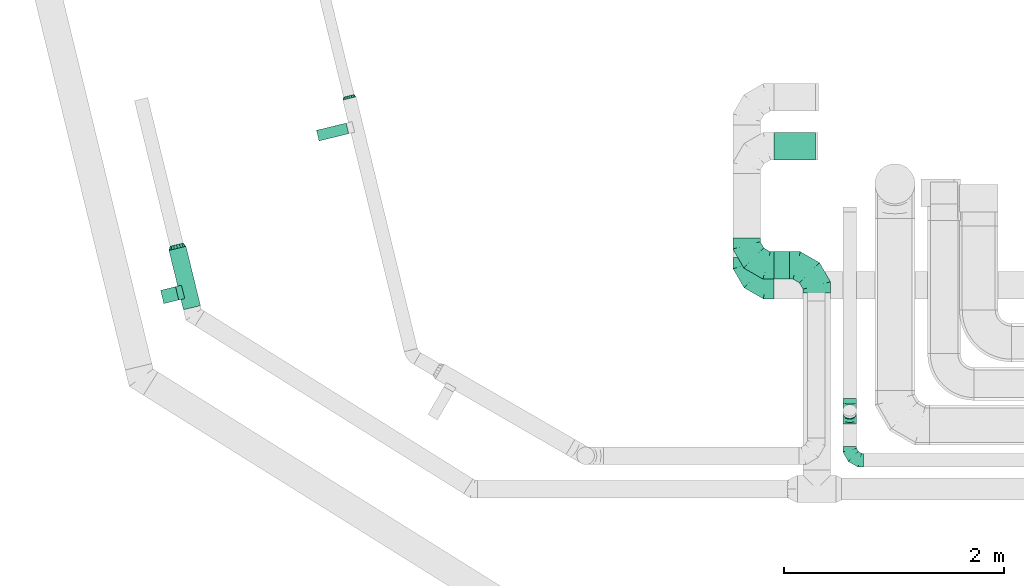
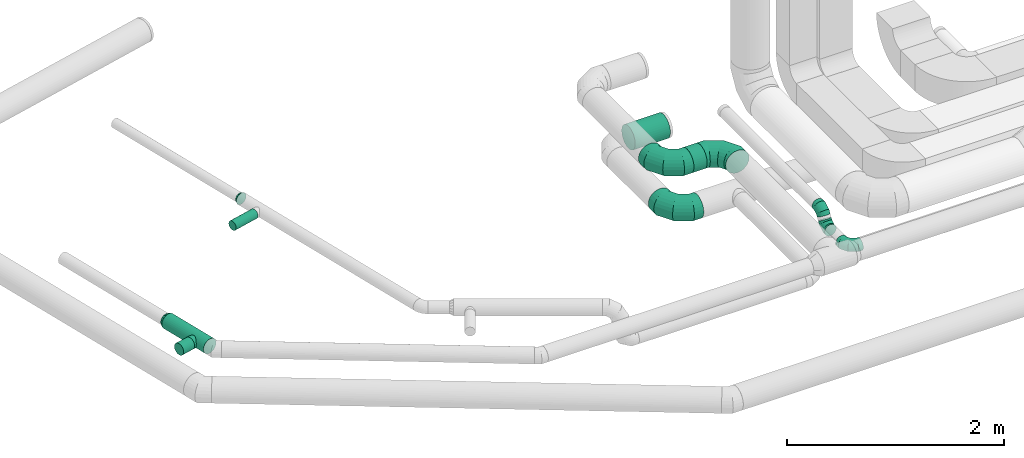
# One storey, part 36 of 92: 9 flow fittings, 5 flow segments.
"""IFC2X3 building model written with IfcOpenShell, lengths in millimetres."""

from ifc_helpers import new_model, entity, si_unit, converted_unit, derived_unit, direction, frame, origin, origin_2d_with_axis, place, context, subcontext, project, spatial, circle, extrude, faceted_brep, source, transform, mapped, material, type_object, type_shapes, element, save


model = new_model("IFC2X3")

# Units and contexts
model_context = context("Model", 3, precision=0.01, world=origin(), true_north=direction((6.12303176911189e-17, 1.0)))
body_context = subcontext(model_context, "Body", "Model", "MODEL_VIEW")
ifc_project = project(units=[si_unit("LENGTHUNIT", "METRE", prefix="MILLI"), si_unit("AREAUNIT", "SQUARE_METRE"), si_unit("VOLUMEUNIT", "CUBIC_METRE"), converted_unit("PLANEANGLEUNIT", "DEGREE", entity("IfcRatioMeasure", 0.0174532925199433), si_unit("PLANEANGLEUNIT", "RADIAN"), dimensions=[0, 0, 0, 0, 0, 0, 0]), si_unit("MASSUNIT", "GRAM", prefix="KILO"), derived_unit("MASSDENSITYUNIT", [(si_unit("MASSUNIT", "GRAM", prefix="KILO"), 1), (si_unit("LENGTHUNIT", "METRE"), -3)]), derived_unit("MOMENTOFINERTIAUNIT", [(si_unit("LENGTHUNIT", "METRE"), 4)]), si_unit("TIMEUNIT", "SECOND"), si_unit("FREQUENCYUNIT", "HERTZ"), si_unit("THERMODYNAMICTEMPERATUREUNIT", "DEGREE_CELSIUS"), derived_unit("THERMALTRANSMITTANCEUNIT", [(si_unit("MASSUNIT", "GRAM", prefix="KILO"), 1), (si_unit("THERMODYNAMICTEMPERATUREUNIT", "KELVIN"), -1), (si_unit("TIMEUNIT", "SECOND"), -3)]), derived_unit("VOLUMETRICFLOWRATEUNIT", [(si_unit("LENGTHUNIT", "METRE"), 3), (si_unit("TIMEUNIT", "SECOND"), -1)]), derived_unit("MASSFLOWRATEUNIT", [(si_unit("MASSUNIT", "GRAM", prefix="KILO"), 1), (si_unit("TIMEUNIT", "SECOND"), -1)]), derived_unit("ROTATIONALFREQUENCYUNIT", [(si_unit("TIMEUNIT", "SECOND"), -1)]), si_unit("ELECTRICCURRENTUNIT", "AMPERE"), si_unit("ELECTRICVOLTAGEUNIT", "VOLT"), si_unit("POWERUNIT", "WATT"), si_unit("FORCEUNIT", "NEWTON", prefix="KILO"), si_unit("ILLUMINANCEUNIT", "LUX"), si_unit("LUMINOUSFLUXUNIT", "LUMEN"), si_unit("LUMINOUSINTENSITYUNIT", "CANDELA"), derived_unit("USERDEFINED", [(si_unit("MASSUNIT", "GRAM", prefix="KILO"), -1), (si_unit("LENGTHUNIT", "METRE"), -2), (si_unit("TIMEUNIT", "SECOND"), 3), (si_unit("LUMINOUSFLUXUNIT", "LUMEN"), 1)]), derived_unit("LINEARVELOCITYUNIT", [(si_unit("LENGTHUNIT", "METRE"), 1), (si_unit("TIMEUNIT", "SECOND"), -1)]), si_unit("PRESSUREUNIT", "PASCAL"), derived_unit("USERDEFINED", [(si_unit("LENGTHUNIT", "METRE"), -2), (si_unit("MASSUNIT", "GRAM", prefix="KILO"), 1), (si_unit("TIMEUNIT", "SECOND"), -2)]), derived_unit("LINEARFORCEUNIT", [(si_unit("MASSUNIT", "GRAM", prefix="KILO"), 1), (si_unit("LENGTHUNIT", "METRE"), 1), (si_unit("TIMEUNIT", "SECOND"), -2), (si_unit("LENGTHUNIT", "METRE"), -1)]), derived_unit("PLANARFORCEUNIT", [(si_unit("MASSUNIT", "GRAM", prefix="KILO"), 1), (si_unit("LENGTHUNIT", "METRE"), 1), (si_unit("TIMEUNIT", "SECOND"), -2), (si_unit("LENGTHUNIT", "METRE"), -2)])], contexts=[model_context])

# Site, building, storey
site_placement = place(None, origin())
site = spatial("IfcSite", under=ifc_project, at=site_placement, CompositionType="ELEMENT")
building_placement = place(site_placement, origin())
building = spatial("IfcBuilding", under=site, at=building_placement, CompositionType="ELEMENT")
storey_placement = place(building_placement, frame((0.0, 0.0, 4200.0)))
storey = spatial("IfcBuildingStorey", under=building, at=storey_placement, CompositionType="ELEMENT", Elevation=4200.0)

# Flow segments
duct_segment_type = type_object("IfcDuctSegmentType", PredefinedType="NOTDEFINED")
flow_segment_1_placement = place(storey_placement, frame((1987.11, 12867.99, 3218.4)))
element("IfcFlowSegment", 1, at=flow_segment_1_placement, inside=storey, type_object=duct_segment_type, context=body_context, shape_type="SweptSolid", body=[
    extrude(circle(Radius=80.0, at=origin_2d_with_axis()), frame((79.32, 560.84, 81.6), z_axis=(0.236826092990331, -0.971552058141475, 0.0), x_axis=(0.971552058141475, 0.236826092990331, 0.0)), (0.0, 0.0, 1.0), 556.118650423203),
])
flow_segment_2_placement = place(storey_placement, frame((1910.85, 12924.11, 3235.9)))
element("IfcFlowSegment", 2, at=flow_segment_2_placement, inside=storey, type_object=duct_segment_type, context=body_context, shape_type="SweptSolid", body=[
    extrude(circle(Radius=62.5, at=origin_2d_with_axis()), frame((16.4, 62.32, 64.1), z_axis=(0.971552058141405, 0.236826092990615, 0.0), x_axis=(-0.236826092990615, 0.971552058141405, 0.0)), (0.0, 0.0, 1.0), 140.00000000002),
])
flow_segment_3_placement = place(storey_placement, frame((7501.8, 14233.04, 2773.4)))
element("IfcFlowSegment", 3, at=flow_segment_3_placement, inside=storey, type_object=duct_segment_type, context=body_context, shape_type="SweptSolid", body=[
    extrude(circle(Radius=125.0, at=origin_2d_with_axis()), frame((0.0, 126.6, 126.6), z_axis=(1.0, 0.0, 0.0), x_axis=(0.0, -1.0, 0.0)), (0.0, 0.0, 1.0), 374.869370000043),
])
flow_segment_4_placement = place(storey_placement, frame((3330.66, 14405.86, 3251.25)))
element("IfcFlowSegment", 4, at=flow_segment_4_placement, inside=storey, type_object=duct_segment_type, context=body_context, shape_type="SweptSolid", body=[
    extrude(circle(Radius=50.0, at=origin_2d_with_axis()), frame((13.43, 50.17, 51.6), z_axis=(0.971566689307943, 0.236766062236974, 0.0), x_axis=(-0.236766062236974, 0.971566689307943, 0.0)), (0.0, 0.0, 1.0), 278.877035459787),
])
flow_segment_5_placement = place(storey_placement, frame((7500.09, 13147.27, 3173.4)))
element("IfcFlowSegment", 5, at=flow_segment_5_placement, inside=storey, type_object=duct_segment_type, context=body_context, shape_type="SweptSolid", body=[
    extrude(circle(Radius=125.0, at=origin_2d_with_axis()), frame((0.0, 126.6, 126.6), z_axis=(1.0, 0.0, 0.0), x_axis=(0.0, 1.0, 0.0)), (0.0, 0.0, 1.0), 140.00000000002),
])

# Flow fittings
ifc_material = material()
duct_fitting_type_1 = type_object("IfcDuctFittingType", PredefinedType="NOTDEFINED", material=ifc_material)
shared_shape_1 = source(origin(), body_context, "Body", "Brep", [
    faceted_brep([(-250.0, 0.0, -125.0), (-250.0, -32.35, -120.74), (-250.0, -62.5, -108.25), (-250.0, -88.39, -88.39), (-250.0, -108.25, -62.5), (-250.0, -120.74, -32.35), (-250.0, -125.0, 0.0), (-250.0, -120.74, 32.35), (-250.0, -108.25, 62.5), (-250.0, -88.39, 88.39), (-250.0, -62.5, 108.25), (-250.0, -32.35, 120.74), (-250.0, 0.0, 125.0), (-250.0, 32.35, 120.74), (-250.0, 62.5, 108.25), (-250.0, 88.39, 88.39), (-250.0, 108.25, 62.5), (-250.0, 120.74, 32.35), (-250.0, 125.0, 0.0), (-250.0, 120.74, -32.35), (-250.0, 108.25, -62.5), (-250.0, 88.39, -88.39), (-250.0, 62.5, -108.25), (-250.0, 32.35, -120.74), (-191.68, 32.35, 120.74), (-199.76, 62.5, 108.25), (-183.01, 0.0, 125.0), (-206.7, 88.39, 88.39), (-215.37, 120.74, 32.35), (-216.51, 125.0, 0.0), (-212.02, 108.25, 62.5), (-212.02, 108.25, -62.5), (-206.7, 88.39, -88.39), (-215.37, 120.74, -32.35), (-191.68, 32.35, -120.74), (-183.01, 0.0, -125.0), (-199.76, 62.5, -108.25), (-174.34, -32.35, -120.74), (-166.27, -62.5, -108.25), (-159.33, -88.39, -88.39), (-154.01, -108.25, -62.5), (-150.66, -120.74, -32.35), (-149.52, -125.0, 0.0), (-150.66, -120.74, 32.35), (-154.01, -108.25, 62.5), (-159.33, -88.39, 88.39), (-166.27, -62.5, 108.25), (-174.34, -32.35, 120.74), (-90.67, 90.67, 120.74), (-112.74, 112.74, 108.25), (-66.99, 66.99, 125.0), (-131.69, 131.69, 88.39), (-146.23, 146.23, 62.5), (-155.38, 155.38, 32.35), (-158.49, 158.49, 0.0), (-155.38, 155.38, -32.35), (-146.23, 146.23, -62.5), (-131.69, 131.69, -88.39), (-90.67, 90.67, -120.74), (-66.99, 66.99, -125.0), (-112.74, 112.74, -108.25), (-43.3, 43.3, -120.74), (-21.23, 21.23, -108.25), (-2.28, 2.28, -88.39), (12.26, -12.26, -62.5), (21.4, -21.4, -32.35), (24.52, -24.52, 0.0), (21.4, -21.4, 32.35), (12.26, -12.26, 62.5), (-2.28, 2.28, 88.39), (-21.23, 21.23, 108.25), (-43.3, 43.3, 120.74), (-32.35, 191.68, 120.74), (-62.5, 199.76, 108.25), (0.0, 183.01, 125.0), (-88.39, 206.7, 88.39), (-108.25, 212.02, 62.5), (-120.74, 215.37, 32.35), (-125.0, 216.51, 0.0), (-120.74, 215.37, -32.35), (-108.25, 212.02, -62.5), (-88.39, 206.7, -88.39), (-32.35, 191.68, -120.74), (0.0, 183.01, -125.0), (-62.5, 199.76, -108.25), (32.35, 174.34, -120.74), (62.5, 166.27, -108.25), (88.39, 159.33, -88.39), (108.25, 154.01, -62.5), (120.74, 150.66, -32.35), (125.0, 149.52, 0.0), (120.74, 150.66, 32.35), (108.25, 154.01, 62.5), (88.39, 159.33, 88.39), (62.5, 166.27, 108.25), (32.35, 174.34, 120.74), (-32.35, 250.0, -120.74), (-62.5, 250.0, -108.25), (-88.39, 250.0, -88.39), (-108.25, 250.0, -62.5), (-120.74, 250.0, -32.35), (-125.0, 250.0, 0.0), (-120.74, 250.0, 32.35), (-108.25, 250.0, 62.5), (-88.39, 250.0, 88.39), (-62.5, 250.0, 108.25), (-32.35, 250.0, 120.74), (0.0, 250.0, 125.0), (32.35, 250.0, 120.74), (62.5, 250.0, 108.25), (88.39, 250.0, 88.39), (108.25, 250.0, 62.5), (120.74, 250.0, 32.35), (125.0, 250.0, 0.0), (120.74, 250.0, -32.35), (108.25, 250.0, -62.5), (88.39, 250.0, -88.39), (62.5, 250.0, -108.25), (32.35, 250.0, -120.74), (0.0, 250.0, -125.0)], [[[0, 1, 2, 3, 4, 5, 6, 7, 8, 9, 10, 11, 12, 13, 14, 15, 16, 17, 18, 19, 20, 21, 22, 23]], [[24, 25, 14, 13]], [[26, 24, 13, 12]], [[14, 25, 27, 15]], [[28, 29, 18, 17]], [[30, 28, 17, 16]], [[15, 27, 30, 16]], [[20, 31, 32, 21]], [[33, 31, 20, 19]], [[18, 29, 33, 19]], [[34, 35, 0, 23]], [[36, 34, 23, 22]], [[21, 32, 36, 22]], [[1, 0, 35, 37]], [[2, 1, 37, 38]], [[38, 39, 3, 2]], [[5, 4, 40, 41]], [[6, 5, 41, 42]], [[39, 40, 4, 3]], [[6, 42, 43, 7]], [[7, 43, 44, 8]], [[8, 44, 45, 9]], [[9, 45, 46, 10]], [[10, 46, 47, 11]], [[26, 12, 11, 47]], [[48, 49, 25, 24]], [[50, 48, 24, 26]], [[27, 25, 49, 51]], [[52, 53, 28, 30]], [[51, 52, 30, 27]], [[29, 28, 53, 54]], [[55, 56, 31, 33]], [[54, 55, 33, 29]], [[32, 31, 56, 57]], [[58, 59, 35, 34]], [[60, 58, 34, 36]], [[57, 60, 36, 32]], [[37, 35, 59, 61]], [[38, 37, 61, 62]], [[39, 38, 62, 63]], [[41, 40, 64, 65]], [[42, 41, 65, 66]], [[63, 64, 40, 39]], [[43, 42, 66, 67]], [[44, 43, 67, 68]], [[68, 69, 45, 44]], [[46, 45, 69, 70]], [[47, 46, 70, 71]], [[26, 47, 71, 50]], [[72, 73, 49, 48]], [[74, 72, 48, 50]], [[51, 49, 73, 75]], [[76, 77, 53, 52]], [[75, 76, 52, 51]], [[54, 53, 77, 78]], [[79, 80, 56, 55]], [[78, 79, 55, 54]], [[57, 56, 80, 81]], [[82, 83, 59, 58]], [[84, 82, 58, 60]], [[81, 84, 60, 57]], [[61, 59, 83, 85]], [[62, 61, 85, 86]], [[63, 62, 86, 87]], [[65, 64, 88, 89]], [[66, 65, 89, 90]], [[87, 88, 64, 63]], [[67, 66, 90, 91]], [[68, 67, 91, 92]], [[92, 93, 69, 68]], [[70, 69, 93, 94]], [[71, 70, 94, 95]], [[50, 71, 95, 74]], [[96, 97, 98, 99, 100, 101, 102, 103, 104, 105, 106, 107, 108, 109, 110, 111, 112, 113, 114, 115, 116, 117, 118, 119]], [[72, 74, 107, 106]], [[73, 72, 106, 105]], [[75, 73, 105, 104]], [[77, 76, 103, 102]], [[78, 77, 102, 101]], [[75, 104, 103, 76]], [[78, 101, 100, 79]], [[79, 100, 99, 80]], [[80, 99, 98, 81]], [[84, 97, 96, 82]], [[82, 96, 119, 83]], [[84, 81, 98, 97]], [[83, 119, 118, 85]], [[85, 118, 117, 86]], [[116, 87, 86, 117]], [[88, 115, 114, 89]], [[89, 114, 113, 90]], [[115, 88, 87, 116]], [[91, 90, 113, 112]], [[92, 91, 112, 111]], [[111, 110, 93, 92]], [[95, 94, 109, 108]], [[74, 95, 108, 107]], [[110, 109, 94, 93]]]),
])
type_shapes(duct_fitting_type_1, [shared_shape_1])
for number, where, z_axis, x_axis in (
    (6, (7250.09, 13273.87, 3300.0), (0.0, 0.0, 1.0), (0.0, -1.0, 0.0)),
    (7, (7890.09, 13273.87, 3300.0), (0.0, 0.0, 1.0), (0.0, 1.0, 0.0)),
    (8, (7251.8, 13095.03, 2900.0), (0.0, 0.0, 1.0), (0.0, -1.0, 0.0)),
):
    element("IfcFlowFitting", number, at=place(storey_placement, frame(where, z_axis=z_axis, x_axis=x_axis)), inside=storey, type_object=duct_fitting_type_1, material=ifc_material, context=body_context, shape_type="MappedRepresentation", body=[
        mapped(shared_shape_1, transform((0.0, 0.0, 0.0), scale=1.0)),
    ])
duct_fitting_type_2 = type_object("IfcDuctFittingType", PredefinedType="NOTDEFINED", material=ifc_material)
shared_shape_2 = source(origin(), body_context, "Body", "Brep", [
    faceted_brep([(-125.0, 0.0, -62.5), (-125.0, -16.18, -60.37), (-125.0, -31.25, -54.13), (-125.0, -44.19, -44.19), (-125.0, -54.13, -31.25), (-125.0, -60.37, -16.18), (-125.0, -62.5, 0.0), (-125.0, -60.37, 16.18), (-125.0, -54.13, 31.25), (-125.0, -44.19, 44.19), (-125.0, -31.25, 54.13), (-125.0, -16.18, 60.37), (-125.0, 0.0, 62.5), (-125.0, 16.18, 60.37), (-125.0, 31.25, 54.13), (-125.0, 44.19, 44.19), (-125.0, 54.13, 31.25), (-125.0, 60.37, 16.18), (-125.0, 62.5, 0.0), (-125.0, 60.37, -16.18), (-125.0, 54.13, -31.25), (-125.0, 44.19, -44.19), (-125.0, 31.25, -54.13), (-125.0, 16.18, -60.37), (-95.84, 16.18, 60.37), (-99.88, 31.25, 54.13), (-91.51, 0.0, 62.5), (-103.35, 44.19, 44.19), (-107.68, 60.37, 16.18), (-108.25, 62.5, 0.0), (-106.01, 54.13, 31.25), (-106.01, 54.13, -31.25), (-103.35, 44.19, -44.19), (-107.68, 60.37, -16.18), (-95.84, 16.18, -60.37), (-91.51, 0.0, -62.5), (-99.88, 31.25, -54.13), (-87.17, -16.18, -60.37), (-83.13, -31.25, -54.13), (-79.66, -44.19, -44.19), (-77.0, -54.13, -31.25), (-75.33, -60.37, -16.18), (-74.76, -62.5, 0.0), (-75.33, -60.37, 16.18), (-77.0, -54.13, 31.25), (-79.66, -44.19, 44.19), (-83.13, -31.25, 54.13), (-87.17, -16.18, 60.37), (-45.34, 45.34, 60.37), (-56.37, 56.37, 54.13), (-33.49, 33.49, 62.5), (-65.85, 65.85, 44.19), (-73.12, 73.12, 31.25), (-77.69, 77.69, 16.18), (-79.25, 79.25, 0.0), (-77.69, 77.69, -16.18), (-73.12, 73.12, -31.25), (-65.85, 65.85, -44.19), (-45.34, 45.34, -60.37), (-33.49, 33.49, -62.5), (-56.37, 56.37, -54.13), (-21.65, 21.65, -60.37), (-10.62, 10.62, -54.13), (-1.14, 1.14, -44.19), (6.13, -6.13, -31.25), (10.7, -10.7, -16.18), (12.26, -12.26, 0.0), (10.7, -10.7, 16.18), (6.13, -6.13, 31.25), (-1.14, 1.14, 44.19), (-10.62, 10.62, 54.13), (-21.65, 21.65, 60.37), (-16.18, 95.84, 60.37), (-31.25, 99.88, 54.13), (0.0, 91.51, 62.5), (-44.19, 103.35, 44.19), (-54.13, 106.01, 31.25), (-60.37, 107.68, 16.18), (-62.5, 108.25, 0.0), (-60.37, 107.68, -16.18), (-54.13, 106.01, -31.25), (-44.19, 103.35, -44.19), (-16.18, 95.84, -60.37), (0.0, 91.51, -62.5), (-31.25, 99.88, -54.13), (16.18, 87.17, -60.37), (31.25, 83.13, -54.13), (44.19, 79.66, -44.19), (54.13, 77.0, -31.25), (60.37, 75.33, -16.18), (62.5, 74.76, 0.0), (60.37, 75.33, 16.18), (54.13, 77.0, 31.25), (44.19, 79.66, 44.19), (31.25, 83.13, 54.13), (16.18, 87.17, 60.37), (-16.18, 125.0, -60.37), (-31.25, 125.0, -54.13), (-44.19, 125.0, -44.19), (-54.13, 125.0, -31.25), (-60.37, 125.0, -16.18), (-62.5, 125.0, 0.0), (-60.37, 125.0, 16.18), (-54.13, 125.0, 31.25), (-44.19, 125.0, 44.19), (-31.25, 125.0, 54.13), (-16.18, 125.0, 60.37), (0.0, 125.0, 62.5), (16.18, 125.0, 60.37), (31.25, 125.0, 54.13), (44.19, 125.0, 44.19), (54.13, 125.0, 31.25), (60.37, 125.0, 16.18), (62.5, 125.0, 0.0), (60.37, 125.0, -16.18), (54.13, 125.0, -31.25), (44.19, 125.0, -44.19), (31.25, 125.0, -54.13), (16.18, 125.0, -60.37), (0.0, 125.0, -62.5)], [[[0, 1, 2, 3, 4, 5, 6, 7, 8, 9, 10, 11, 12, 13, 14, 15, 16, 17, 18, 19, 20, 21, 22, 23]], [[24, 25, 14, 13]], [[26, 24, 13, 12]], [[14, 25, 27, 15]], [[28, 29, 18, 17]], [[30, 28, 17, 16]], [[15, 27, 30, 16]], [[20, 31, 32, 21]], [[33, 31, 20, 19]], [[18, 29, 33, 19]], [[34, 35, 0, 23]], [[36, 34, 23, 22]], [[21, 32, 36, 22]], [[1, 0, 35, 37]], [[2, 1, 37, 38]], [[38, 39, 3, 2]], [[5, 4, 40, 41]], [[6, 5, 41, 42]], [[39, 40, 4, 3]], [[6, 42, 43, 7]], [[7, 43, 44, 8]], [[45, 9, 8, 44]], [[9, 45, 46, 10]], [[10, 46, 47, 11]], [[26, 12, 11, 47]], [[48, 49, 25, 24]], [[50, 48, 24, 26]], [[27, 25, 49, 51]], [[52, 53, 28, 30]], [[51, 52, 30, 27]], [[29, 28, 53, 54]], [[55, 56, 31, 33]], [[54, 55, 33, 29]], [[57, 32, 31, 56]], [[58, 59, 35, 34]], [[60, 58, 34, 36]], [[57, 60, 36, 32]], [[37, 35, 59, 61]], [[38, 37, 61, 62]], [[39, 38, 62, 63]], [[41, 40, 64, 65]], [[42, 41, 65, 66]], [[63, 64, 40, 39]], [[43, 42, 66, 67]], [[44, 43, 67, 68]], [[68, 69, 45, 44]], [[46, 45, 69, 70]], [[47, 46, 70, 71]], [[26, 47, 71, 50]], [[72, 73, 49, 48]], [[74, 72, 48, 50]], [[51, 49, 73, 75]], [[76, 77, 53, 52]], [[75, 76, 52, 51]], [[54, 53, 77, 78]], [[79, 80, 56, 55]], [[78, 79, 55, 54]], [[81, 57, 56, 80]], [[82, 83, 59, 58]], [[84, 82, 58, 60]], [[81, 84, 60, 57]], [[61, 59, 83, 85]], [[62, 61, 85, 86]], [[63, 62, 86, 87]], [[65, 64, 88, 89]], [[66, 65, 89, 90]], [[87, 88, 64, 63]], [[67, 66, 90, 91]], [[68, 67, 91, 92]], [[92, 93, 69, 68]], [[70, 69, 93, 94]], [[71, 70, 94, 95]], [[50, 71, 95, 74]], [[96, 97, 98, 99, 100, 101, 102, 103, 104, 105, 106, 107, 108, 109, 110, 111, 112, 113, 114, 115, 116, 117, 118, 119]], [[72, 74, 107, 106]], [[73, 72, 106, 105]], [[75, 73, 105, 104]], [[77, 76, 103, 102]], [[78, 77, 102, 101]], [[75, 104, 103, 76]], [[78, 101, 100, 79]], [[79, 100, 99, 80]], [[80, 99, 98, 81]], [[96, 119, 83, 82]], [[97, 96, 82, 84]], [[84, 81, 98, 97]], [[83, 119, 118, 85]], [[85, 118, 117, 86]], [[116, 87, 86, 117]], [[88, 115, 114, 89]], [[89, 114, 113, 90]], [[115, 88, 87, 116]], [[91, 90, 113, 112]], [[92, 91, 112, 111]], [[111, 110, 93, 92]], [[95, 94, 109, 108]], [[74, 95, 108, 107]], [[110, 109, 94, 93]]]),
])
type_shapes(duct_fitting_type_2, [shared_shape_2])
flow_fitting_1_placement = place(storey_placement, frame((8189.69, 11499.68, 3150.0), z_axis=(0.0, 0.0, 1.0), x_axis=(0.0, -1.0, 0.0)))
element("IfcFlowFitting", 9, at=flow_fitting_1_placement, inside=storey, type_object=duct_fitting_type_2, material=ifc_material, context=body_context, shape_type="MappedRepresentation", body=[
    mapped(shared_shape_2, transform((0.0, 0.0, 0.0), scale=1.0)),
])
duct_fitting_type_3 = type_object("IfcDuctFittingType", PredefinedType="NOTDEFINED", material=ifc_material)
shared_shape_3 = source(origin(), body_context, "Body", "Brep", [
    faceted_brep([(35.0, -57.74, 23.92), (35.0, -60.12, 11.96), (35.0, -62.5, 0.0), (35.0, -60.12, -11.96), (35.0, -57.74, -23.92), (35.0, -50.97, -34.06), (35.0, -44.19, -44.19), (35.0, -34.06, -50.97), (35.0, -23.92, -57.74), (35.0, -11.96, -60.12), (35.0, 0.0, -62.5), (35.0, 11.96, -60.12), (35.0, 23.92, -57.74), (35.0, 34.06, -50.97), (35.0, 44.19, -44.19), (35.0, 50.97, -34.06), (35.0, 57.74, -23.92), (35.0, 60.12, -11.96), (35.0, 62.5, 0.0), (35.0, 60.12, 11.96), (35.0, 57.74, 23.92), (35.0, 50.97, 34.06), (35.0, 44.19, 44.19), (35.0, 34.06, 50.97), (35.0, 23.92, 57.74), (35.0, 11.96, 60.12), (35.0, 0.0, 62.5), (35.0, -11.96, 60.12), (35.0, -23.92, 57.74), (35.0, -34.06, 50.97), (35.0, -44.19, 44.19), (35.0, -50.97, 34.06), (0.0, -80.0, 0.0), (0.0, -77.45, 12.81), (0.0, -73.91, 30.61), (0.0, -65.24, 43.59), (0.0, -56.57, 56.57), (0.0, -43.59, 65.24), (0.0, -30.61, 73.91), (0.0, -12.81, 77.45), (0.0, 0.0, 80.0), (0.0, 12.81, 77.45), (0.0, 30.61, 73.91), (0.0, 43.59, 65.24), (0.0, 56.57, 56.57), (0.0, 65.24, 43.59), (0.0, 73.91, 30.61), (0.0, 77.45, 12.81), (0.0, 80.0, 0.0), (0.0, 77.45, -12.81), (0.0, 73.91, -30.61), (0.0, 65.24, -43.59), (0.0, 56.57, -56.57), (0.0, 43.59, -65.24), (0.0, 30.61, -73.91), (0.0, 12.81, -77.45), (0.0, 0.0, -80.0), (0.0, -12.81, -77.45), (0.0, -30.61, -73.91), (0.0, -43.59, -65.24), (0.0, -56.57, -56.57), (0.0, -65.24, -43.59), (0.0, -73.91, -30.61), (0.0, -77.45, -12.81)], [[[0, 1, 2, 3, 4, 5, 6, 7, 8, 9, 10, 11, 12, 13, 14, 15, 16, 17, 18, 19, 20, 21, 22, 23, 24, 25, 26, 27, 28, 29, 30, 31]], [[32, 33, 34, 35, 36, 37, 38, 39, 40, 41, 42, 43, 44, 45, 46, 47, 48, 49, 50, 51, 52, 53, 54, 55, 56, 57, 58, 59, 60, 61, 62, 63]], [[24, 23, 22, 44, 43, 42]], [[20, 46, 45, 44, 22, 21]], [[42, 41, 40, 26, 25, 24]], [[47, 46, 20, 19, 18, 48]], [[0, 31, 30, 36, 35, 34]], [[28, 38, 37, 36, 30, 29]], [[34, 33, 32, 2, 1, 0]], [[39, 38, 28, 27, 26, 40]], [[8, 7, 6, 60, 59, 58]], [[4, 62, 61, 60, 6, 5]], [[58, 57, 56, 10, 9, 8]], [[63, 62, 4, 3, 2, 32]], [[16, 15, 14, 52, 51, 50]], [[12, 54, 53, 52, 14, 13]], [[50, 49, 48, 18, 17, 16]], [[55, 54, 12, 11, 10, 56]]]),
])
type_shapes(duct_fitting_type_3, [shared_shape_3])
flow_fitting_2_placement = place(storey_placement, frame((2066.43, 13428.83, 3300.0), z_axis=(0.0, 0.0, 1.0), x_axis=(-0.236826092990331, 0.971552058141475, 0.0)))
element("IfcFlowFitting", 10, at=flow_fitting_2_placement, inside=storey, type_object=duct_fitting_type_3, material=ifc_material, context=body_context, shape_type="MappedRepresentation", body=[
    mapped(shared_shape_3, transform((0.0, 0.0, 0.0), scale=1.0)),
])
duct_fitting_type_4 = type_object("IfcDuctFittingType", PredefinedType="NOTDEFINED", material=ifc_material)
shared_shape_4 = source(origin(), body_context, "Body", "Brep", [
    faceted_brep([(25.0, -46.19, 19.13), (25.0, -48.1, 9.57), (25.0, -50.0, 0.0), (25.0, -48.1, -9.57), (25.0, -46.19, -19.13), (25.0, -40.77, -27.24), (25.0, -35.36, -35.36), (25.0, -27.24, -40.77), (25.0, -19.13, -46.19), (25.0, -9.57, -48.1), (25.0, 0.0, -50.0), (25.0, 9.57, -48.1), (25.0, 19.13, -46.19), (25.0, 27.24, -40.77), (25.0, 35.36, -35.36), (25.0, 40.77, -27.24), (25.0, 46.19, -19.13), (25.0, 48.1, -9.57), (25.0, 50.0, 0.0), (25.0, 48.1, 9.57), (25.0, 46.19, 19.13), (25.0, 40.77, 27.24), (25.0, 35.36, 35.36), (25.0, 27.24, 40.77), (25.0, 19.13, 46.19), (25.0, 9.57, 48.1), (25.0, 0.0, 50.0), (25.0, -9.57, 48.1), (25.0, -19.13, 46.19), (25.0, -27.24, 40.77), (25.0, -35.36, 35.36), (25.0, -40.77, 27.24), (0.0, -62.5, 0.0), (0.0, -60.02, 12.45), (0.0, -57.74, 23.92), (0.0, -50.97, 34.06), (0.0, -44.19, 44.19), (0.0, -34.06, 50.97), (0.0, -23.92, 57.74), (0.0, -12.45, 60.02), (0.0, 0.0, 62.5), (0.0, 12.45, 60.02), (0.0, 23.92, 57.74), (0.0, 34.06, 50.97), (0.0, 44.19, 44.19), (0.0, 50.97, 34.06), (0.0, 57.74, 23.92), (0.0, 60.02, 12.45), (0.0, 62.5, 0.0), (0.0, 60.02, -12.45), (0.0, 57.74, -23.92), (0.0, 50.97, -34.06), (0.0, 44.19, -44.19), (0.0, 34.06, -50.97), (0.0, 23.92, -57.74), (0.0, 12.45, -60.02), (0.0, 0.0, -62.5), (0.0, -12.45, -60.02), (0.0, -23.92, -57.74), (0.0, -34.06, -50.97), (0.0, -44.19, -44.19), (0.0, -50.97, -34.06), (0.0, -57.74, -23.92), (0.0, -60.02, -12.45)], [[[0, 1, 2, 3, 4, 5, 6, 7, 8, 9, 10, 11, 12, 13, 14, 15, 16, 17, 18, 19, 20, 21, 22, 23, 24, 25, 26, 27, 28, 29, 30, 31]], [[32, 33, 34, 35, 36, 37, 38, 39, 40, 41, 42, 43, 44, 45, 46, 47, 48, 49, 50, 51, 52, 53, 54, 55, 56, 57, 58, 59, 60, 61, 62, 63]], [[24, 42, 41, 40, 26, 25]], [[22, 44, 43, 42, 24, 23]], [[48, 47, 46, 20, 19, 18]], [[44, 22, 21, 20, 46, 45]], [[0, 34, 33, 32, 2, 1]], [[30, 36, 35, 34, 0, 31]], [[40, 39, 38, 28, 27, 26]], [[36, 30, 29, 28, 38, 37]], [[8, 58, 57, 56, 10, 9]], [[6, 60, 59, 58, 8, 7]], [[32, 63, 62, 4, 3, 2]], [[60, 6, 5, 4, 62, 61]], [[16, 50, 49, 48, 18, 17]], [[14, 52, 51, 50, 16, 15]], [[56, 55, 54, 12, 11, 10]], [[52, 14, 13, 12, 54, 53]]]),
])
type_shapes(duct_fitting_type_4, [shared_shape_4])
flow_fitting_3_placement = place(storey_placement, frame((3633.51, 14794.48, 3300.0), z_axis=(0.0, 0.0, 1.0), x_axis=(-0.236766062236588, 0.971566689308037, 0.0)))
element("IfcFlowFitting", 11, at=flow_fitting_3_placement, inside=storey, type_object=duct_fitting_type_4, material=ifc_material, context=body_context, shape_type="MappedRepresentation", body=[
    mapped(shared_shape_4, transform((0.0, 0.0, 0.0), scale=1.0)),
])
duct_fitting_type_5 = type_object("IfcDuctFittingType", PredefinedType="NOTDEFINED", material=ifc_material)
shared_shape_5 = source(origin(), body_context, "Body", "Brep", [
    faceted_brep([(20.0, 0.0, -62.5), (20.0, 16.18, -60.37), (20.0, 31.25, -54.13), (20.0, 44.19, -44.19), (20.0, 54.13, -31.25), (20.0, 60.37, -16.18), (20.0, 62.5, 0.0), (20.0, 60.37, 16.18), (20.0, 54.13, 31.25), (20.0, 44.19, 44.19), (20.0, 31.25, 54.13), (20.0, 16.18, 60.37), (20.0, 0.0, 62.5), (20.0, -16.18, 60.37), (20.0, -31.25, 54.13), (20.0, -44.19, 44.19), (20.0, -54.13, 31.25), (20.0, -60.37, 16.18), (20.0, -62.5, 0.0), (20.0, -60.37, -16.18), (20.0, -54.13, -31.25), (20.0, -44.19, -44.19), (20.0, -31.25, -54.13), (20.0, -16.18, -60.37), (0.0, 0.0, 62.5), (-36.16, 0.0, 62.5), (-36.16, -16.18, 60.37), (0.0, -16.18, 60.37), (-36.16, -31.25, 54.13), (0.0, -31.25, 54.13), (0.0, -44.19, 44.19), (-36.16, -44.19, 44.19), (0.0, -54.13, 31.25), (-36.16, -54.13, 31.25), (-36.16, -60.37, 16.18), (0.0, -60.37, 16.18), (-36.16, -62.5, 0.0), (0.0, -62.5, 0.0), (-36.16, -60.37, -16.18), (0.0, -60.37, -16.18), (-36.16, -54.13, -31.25), (0.0, -54.13, -31.25), (0.0, -44.19, -44.19), (-36.16, -44.19, -44.19), (0.0, -31.25, -54.13), (-36.16, -31.25, -54.13), (-36.16, -16.18, -60.37), (0.0, -16.18, -60.37), (-36.16, 0.0, -62.5), (0.0, 0.0, -62.5), (-36.16, 16.18, -60.37), (0.0, 16.18, -60.37), (-36.16, 31.25, -54.13), (0.0, 31.25, -54.13), (0.0, 44.19, -44.19), (-36.16, 44.19, -44.19), (0.0, 54.13, -31.25), (-36.16, 54.13, -31.25), (-36.16, 60.37, -16.18), (0.0, 60.37, -16.18), (-36.16, 62.5, 0.0), (0.0, 62.5, 0.0), (-36.16, 60.37, 16.18), (0.0, 60.37, 16.18), (-36.16, 54.13, 31.25), (0.0, 54.13, 31.25), (0.0, 44.19, 44.19), (-36.16, 44.19, 44.19), (0.0, 31.25, 54.13), (-36.16, 31.25, 54.13), (-36.16, 16.18, 60.37), (0.0, 16.18, 60.37)], [[[0, 1, 2, 3, 4, 5, 6, 7, 8, 9, 10, 11, 12, 13, 14, 15, 16, 17, 18, 19, 20, 21, 22, 23]], [[13, 12, 24, 25, 26, 27]], [[14, 13, 27, 26, 28, 29]], [[30, 15, 14, 29, 28, 31]], [[17, 16, 32, 33, 34, 35]], [[18, 17, 35, 34, 36, 37]], [[32, 16, 15, 30, 31, 33]], [[19, 18, 37, 36, 38, 39]], [[20, 19, 39, 38, 40, 41]], [[42, 21, 20, 41, 40, 43]], [[23, 22, 44, 45, 46, 47]], [[0, 23, 47, 46, 48, 49]], [[44, 22, 21, 42, 43, 45]], [[1, 0, 49, 48, 50, 51]], [[2, 1, 51, 50, 52, 53]], [[54, 3, 2, 53, 52, 55]], [[5, 4, 56, 57, 58, 59]], [[6, 5, 59, 58, 60, 61]], [[56, 4, 3, 54, 55, 57]], [[7, 6, 61, 60, 62, 63]], [[8, 7, 63, 62, 64, 65]], [[66, 9, 8, 65, 64, 67]], [[11, 10, 68, 69, 70, 71]], [[12, 11, 71, 70, 25, 24]], [[68, 10, 9, 66, 67, 69]], [[46, 45, 43, 40, 38, 36, 34, 33, 31, 28, 26, 25, 70, 69, 67, 64, 62, 60, 58, 57, 55, 52, 50, 48]]]),
])
type_shapes(duct_fitting_type_5, [shared_shape_5])
flow_fitting_4_placement = place(storey_placement, frame((2082.69, 13024.32, 3300.0), z_axis=(0.0, 0.0, -1.0), x_axis=(-0.971552058141458, -0.236826092990397, 0.0)))
element("IfcFlowFitting", 12, at=flow_fitting_4_placement, inside=storey, type_object=duct_fitting_type_5, material=ifc_material, context=body_context, shape_type="MappedRepresentation", body=[
    mapped(shared_shape_5, transform((0.0, 0.0, 0.0), scale=1.0)),
])
duct_fitting_type_6 = type_object("IfcDuctFittingType", PredefinedType="NOTDEFINED", material=ifc_material)
shared_shape_6 = source(origin(), body_context, "Body", "Brep", [
    faceted_brep([(-69.97, 0.0, -62.5), (-69.97, -16.18, -60.37), (-69.97, -31.25, -54.13), (-69.97, -44.19, -44.19), (-69.97, -54.13, -31.25), (-69.97, -60.37, -16.18), (-69.97, -62.5, 0.0), (-69.97, -60.37, 16.18), (-69.97, -54.13, 31.25), (-69.97, -44.19, 44.19), (-69.97, -31.25, 54.13), (-69.97, -16.18, 60.37), (-69.97, 0.0, 62.5), (-69.97, 16.18, 60.37), (-69.97, 31.25, 54.13), (-69.97, 44.19, 44.19), (-69.97, 54.13, 31.25), (-69.97, 60.37, 16.18), (-69.97, 62.5, 0.0), (-69.97, 60.37, -16.18), (-69.97, 54.13, -31.25), (-69.97, 44.19, -44.19), (-69.97, 31.25, -54.13), (-69.97, 16.18, -60.37), (-41.59, 16.18, 60.37), (-45.52, 31.25, 54.13), (-37.37, 0.0, 62.5), (-48.89, 44.19, 44.19), (-53.11, 60.37, 16.18), (-53.67, 62.5, 0.0), (-51.48, 54.13, 31.25), (-51.48, 54.13, -31.25), (-48.89, 44.19, -44.19), (-53.11, 60.37, -16.18), (-41.59, 16.18, -60.37), (-37.37, 0.0, -62.5), (-45.52, 31.25, -54.13), (-33.15, -16.18, -60.37), (-29.21, -31.25, -54.13), (-25.84, -44.19, -44.19), (-23.25, -54.13, -31.25), (-21.62, -60.37, -16.18), (-21.06, -62.5, 0.0), (-21.62, -60.37, 16.18), (-23.25, -54.13, 31.25), (-25.84, -44.19, 44.19), (-29.21, -31.25, 54.13), (-33.15, -16.18, 60.37), (7.95, 43.91, 60.37), (-2.84, 55.14, 54.13), (19.54, 31.85, 62.5), (-12.11, 64.79, 44.19), (-19.22, 72.19, 31.25), (-23.69, 76.84, 16.18), (-25.22, 78.43, 0.0), (-23.69, 76.84, -16.18), (-19.22, 72.19, -31.25), (-12.11, 64.79, -44.19), (7.95, 43.91, -60.37), (19.54, 31.85, -62.5), (-2.84, 55.14, -54.13), (31.12, 19.8, -60.37), (41.91, 8.57, -54.13), (51.18, -1.08, -44.19), (58.29, -8.48, -31.25), (62.77, -13.13, -16.18), (64.29, -14.72, 0.0), (62.77, -13.13, 16.18), (58.29, -8.48, 31.25), (51.18, -1.08, 44.19), (41.91, 8.57, 54.13), (31.12, 19.8, 60.37), (36.58, 59.65, 62.5), (22.79, 68.1, 60.37), (9.94, 75.98, 54.13), (-1.09, 82.75, 44.19), (-9.56, 87.95, 31.25), (-14.88, 91.21, 16.18), (-16.69, 92.32, 0.0), (-14.88, 91.21, -16.18), (-9.56, 87.95, -31.25), (-1.09, 82.75, -44.19), (22.79, 68.1, -60.37), (36.58, 59.65, -62.5), (9.94, 75.98, -54.13), (50.37, 51.19, -60.37), (63.22, 43.31, -54.13), (74.26, 36.54, -44.19), (82.72, 31.35, -31.25), (88.05, 28.08, -16.18), (89.86, 26.97, 0.0), (88.05, 28.08, 16.18), (82.72, 31.35, 31.25), (74.26, 36.54, 44.19), (63.22, 43.31, 54.13), (50.37, 51.19, 60.37)], [[[0, 1, 2, 3, 4, 5, 6, 7, 8, 9, 10, 11, 12, 13, 14, 15, 16, 17, 18, 19, 20, 21, 22, 23]], [[24, 25, 14, 13]], [[26, 24, 13, 12]], [[14, 25, 27, 15]], [[28, 29, 18, 17]], [[30, 28, 17, 16]], [[15, 27, 30, 16]], [[20, 31, 32, 21]], [[33, 31, 20, 19]], [[18, 29, 33, 19]], [[34, 35, 0, 23]], [[36, 34, 23, 22]], [[21, 32, 36, 22]], [[1, 0, 35, 37]], [[2, 1, 37, 38]], [[3, 2, 38, 39]], [[5, 4, 40, 41]], [[6, 5, 41, 42]], [[39, 40, 4, 3]], [[6, 42, 43, 7]], [[7, 43, 44, 8]], [[45, 9, 8, 44]], [[9, 45, 46, 10]], [[10, 46, 47, 11]], [[26, 12, 11, 47]], [[48, 49, 25, 24]], [[50, 48, 24, 26]], [[27, 25, 49, 51]], [[52, 53, 28, 30]], [[51, 52, 30, 27]], [[29, 28, 53, 54]], [[55, 56, 31, 33]], [[54, 55, 33, 29]], [[57, 32, 31, 56]], [[58, 59, 35, 34]], [[60, 58, 34, 36]], [[57, 60, 36, 32]], [[37, 35, 59, 61]], [[38, 37, 61, 62]], [[39, 38, 62, 63]], [[41, 40, 64, 65]], [[42, 41, 65, 66]], [[63, 64, 40, 39]], [[43, 42, 66, 67]], [[44, 43, 67, 68]], [[68, 69, 45, 44]], [[46, 45, 69, 70]], [[47, 46, 70, 71]], [[26, 47, 71, 50]], [[48, 50, 72, 73]], [[49, 48, 73, 74]], [[51, 49, 74, 75]], [[53, 52, 76, 77]], [[54, 53, 77, 78]], [[51, 75, 76, 52]], [[54, 78, 79, 55]], [[55, 79, 80, 56]], [[56, 80, 81, 57]], [[82, 83, 59, 58]], [[84, 82, 58, 60]], [[60, 57, 81, 84]], [[59, 83, 85, 61]], [[61, 85, 86, 62]], [[87, 63, 62, 86]], [[64, 88, 89, 65]], [[65, 89, 90, 66]], [[88, 64, 63, 87]], [[67, 66, 90, 91]], [[68, 67, 91, 92]], [[92, 93, 69, 68]], [[71, 70, 94, 95]], [[50, 71, 95, 72]], [[93, 94, 70, 69]], [[82, 84, 81, 80, 79, 78, 77, 76, 75, 74, 73, 72, 95, 94, 93, 92, 91, 90, 89, 88, 87, 86, 85, 83]]]),
])
type_shapes(duct_fitting_type_6, [shared_shape_6])
for number, where, z_axis, x_axis in (
    (13, (8189.69, 11897.85, 3150.0), (1.0, 0.0, 0.0), (0.0, 1.0, 0.0)),
    (14, (8189.69, 11989.85, 3300.0), (1.0, 0.0, 0.0), (0.0, -1.0, 0.0)),
):
    element("IfcFlowFitting", number, at=place(storey_placement, frame(where, z_axis=z_axis, x_axis=x_axis)), inside=storey, type_object=duct_fitting_type_6, material=ifc_material, context=body_context, shape_type="MappedRepresentation", body=[
        mapped(shared_shape_6, transform((0.0, 0.0, 0.0), scale=1.0)),
    ])

save(model, "model.ifc")
